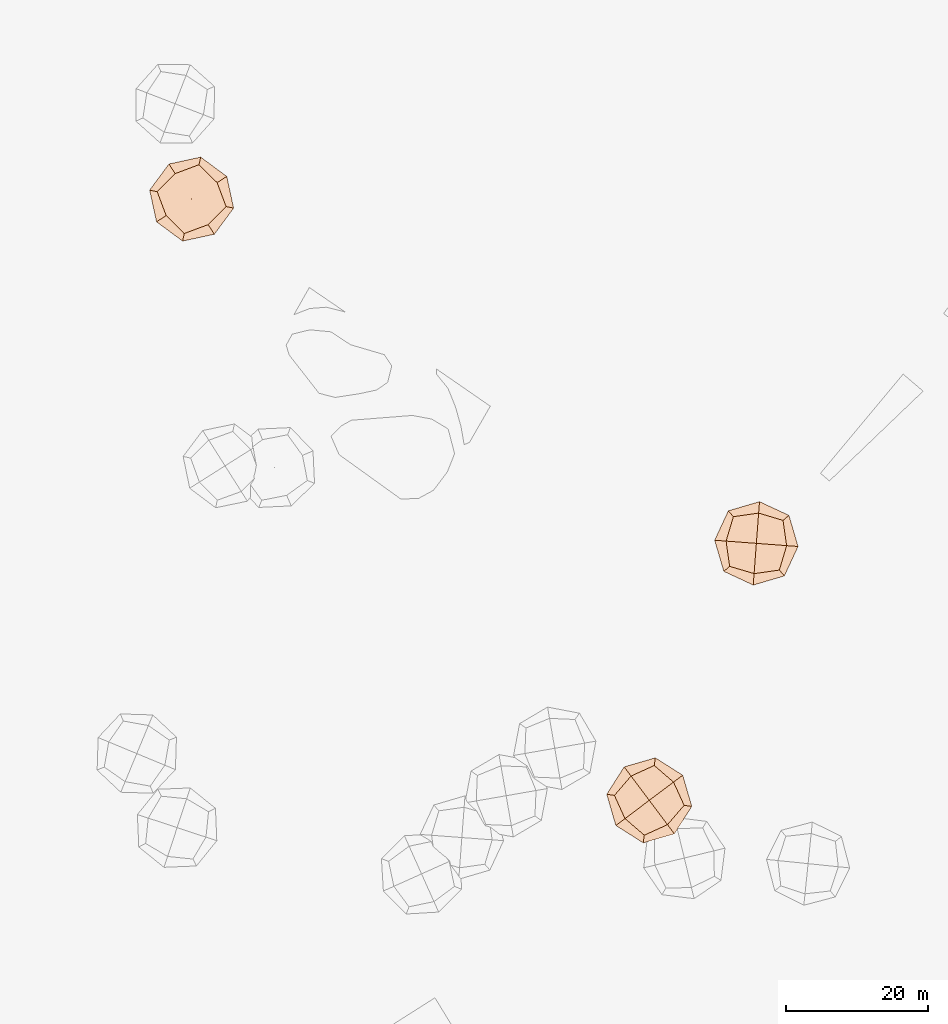
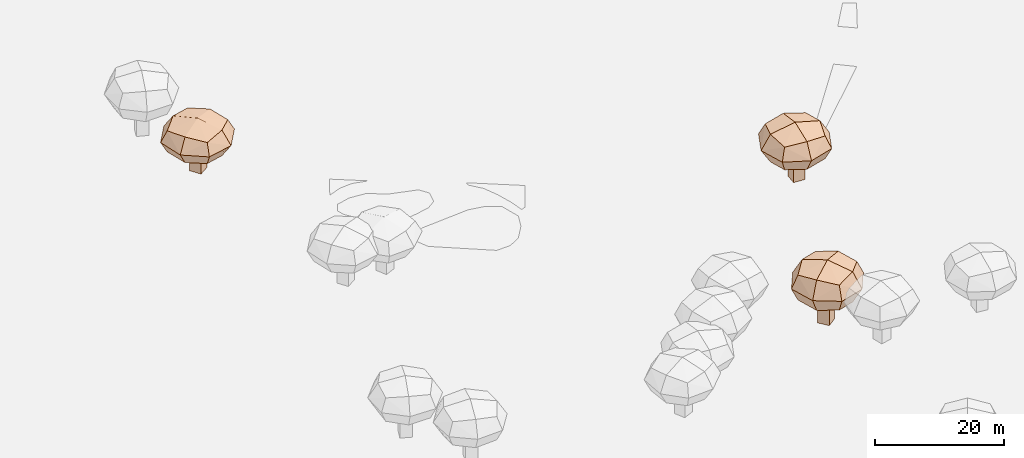
# Not in any storey, part 13 of 92: 3 geographic elements.
"""IFC4 model written with IfcOpenShell, lengths in metres."""

from ifc_helpers import new_model, si_unit, origin_with_axes, place, context, subcontext, project, spatial, triangles, material, element, save


model = new_model("IFC4")

# Units and contexts
model_context = context("Model", 3, precision=1e-05, world=origin_with_axes())
body_context = subcontext(model_context, "Body", "Model", "MODEL_VIEW")
ifc_project = project(units=[si_unit("VOLUMEUNIT", "CUBIC_METRE"), si_unit("LENGTHUNIT", "METRE"), si_unit("AREAUNIT", "SQUARE_METRE")], contexts=[model_context])

# Site
site_placement = place(None, origin_with_axes())
site = spatial("IfcSite", under=ifc_project, at=site_placement)

# Geographic elements
ifc_material = material(Name="tree")
geographic_element_1_placement = place(site_placement, origin_with_axes())
element("IfcGeographicElement", 1, at=geographic_element_1_placement, inside=site, material=ifc_material, Name="cw_instances_tree_165", context=body_context, shape_type="Tessellation", body=[
    triangles([(401.34333958082, -677.0755719799109, 5.6950024270316195), (401.34333958082, -677.0755719799109, 5.6950024270316195), (401.34333958082, -677.0755719799109, 5.6950024270316195), (401.34333958082, -677.0755719799109, 0.0), (401.34333958082, -677.0755719799109, 0.0), (401.34333958082, -677.0755719799109, 0.0), (402.4290647832255, -678.7552150327235, 5.6950024270316195), (402.4290647832255, -678.7552150327235, 5.6950024270316195), (402.4290647832255, -678.7552150327235, 5.6950024270316195), (402.4290647832255, -678.7552150327235, 0.0), (402.4290647832255, -678.7552150327235, 0.0), (402.4290647832255, -678.7552150327235, 0.0), (399.6636965280074, -678.1612971823165, 5.6950024270316195), (399.6636965280074, -678.1612971823165, 5.6950024270316195), (399.6636965280074, -678.1612971823165, 5.6950024270316195), (399.6636965280074, -678.1612971823165, 0.0), (399.6636965280074, -678.1612971823165, 0.0), (399.6636965280074, -678.1612971823165, 0.0), (400.7494217304129, -679.8409402351291, 5.6950024270316195), (400.7494217304129, -679.8409402351291, 5.6950024270316195), (400.7494217304129, -679.8409402351291, 5.6950024270316195), (400.7494217304129, -679.8409402351291, 0.0), (400.7494217304129, -679.8409402351291, 0.0), (400.7494217304129, -679.8409402351291, 0.0), (401.876833048676, -673.7538978813412, 8.483077568031336), (401.876833048676, -673.7538978813412, 8.483077568031336), (401.876833048676, -673.7538978813412, 8.483077568031336), (401.876833048676, -673.7538978813412, 8.483077568031336), (401.876833048676, -673.7538978813412, 8.483077568031336), (401.876833048676, -673.7538978813412, 8.483077568031336), (401.87683298965914, -673.75389734794, 4.49657602856928), (401.87683298965914, -673.75389734794, 4.49657602856928), (401.87683298965914, -673.75389734794, 4.49657602856928), (401.87683298965914, -673.75389734794, 4.49657602856928), (401.87683298965914, -673.75389734794, 4.49657602856928), (401.87683298965914, -673.75389734794, 4.49657602856928), (405.67687055207193, -679.6326470333963, 8.483077568031336), (405.67687055207193, -679.6326470333963, 8.483077568031336), (405.67687055207193, -679.6326470333963, 8.483077568031336), (405.67687055207193, -679.6326470333963, 8.483077568031336), (405.67687055207193, -679.6326470333963, 8.483077568031336), (405.67687055207193, -679.6326470333963, 8.483077568031336), (405.67687055207193, -679.6326470333963, 4.49657602856928), (405.67687055207193, -679.6326470333963, 4.49657602856928), (405.67687055207193, -679.6326470333963, 4.49657602856928), (405.67687055207193, -679.6326470333963, 4.49657602856928), (405.67687055207193, -679.6326470333963, 4.49657602856928), (405.67687055207193, -679.6326470333963, 4.49657602856928), (395.99808269953127, -677.5539353012138, 8.483077568031336), (395.99808269953127, -677.5539353012138, 8.483077568031336), (395.99808269953127, -677.5539353012138, 8.483077568031336), (395.99808269953127, -677.5539353012138, 8.483077568031336), (395.99808269953127, -677.5539353012138, 8.483077568031336), (395.99808269953127, -677.5539353012138, 8.483077568031336), (395.99808310264564, -677.5539350406398, 4.49657602856928), (395.99808310264564, -677.5539350406398, 4.49657602856928), (395.99808310264564, -677.5539350406398, 4.49657602856928), (395.99808310264564, -677.5539350406398, 4.49657602856928), (395.99808310264564, -677.5539350406398, 4.49657602856928), (395.99808310264564, -677.5539350406398, 4.49657602856928), (399.7981203922311, -683.4326851882273, 8.483077568031336), (399.7981203922311, -683.4326851882273, 8.483077568031336), (399.7981203922311, -683.4326851882273, 8.483077568031336), (399.7981203922311, -683.4326851882273, 8.483077568031336), (399.7981203922311, -683.4326851882273, 8.483077568031336), (399.7981203922311, -683.4326851882273, 8.483077568031336), (399.79812026194406, -683.4326849866701, 4.49657602856928), (399.79812026194406, -683.4326849866701, 4.49657602856928), (399.79812026194406, -683.4326849866701, 4.49657602856928), (399.79812026194406, -683.4326849866701, 4.49657602856928), (399.79812026194406, -683.4326849866701, 4.49657602856928), (399.79812026194406, -683.4326849866701, 4.49657602856928), (397.2539795059944, -680.9096722574463, 4.059784066264723), (397.2539795059944, -680.9096722574463, 4.059784066264723), (397.2539795059944, -680.9096722574463, 4.059784066264723), (397.2539795059944, -680.9096722574463, 4.059784066264723), (398.5210959987189, -675.0097944507058, 4.059784066264723), (398.5210959987189, -675.0097944507058, 4.059784066264723), (398.5210959987189, -675.0097944507058, 4.059784066264723), (398.5210959987189, -675.0097944507058, 4.059784066264723), (402.1045927677027, -672.6934137480861, 6.489827140000474), (402.1045927677027, -672.6934137480861, 6.489827140000474), (402.1045927677027, -672.6934137480861, 6.489827140000474), (402.1045927677027, -672.6934137480861, 6.489827140000474), (399.5703602194714, -684.4931690432265, 6.489827140000474), (399.5703602194714, -684.4931690432265, 6.489827140000474), (399.5703602194714, -684.4931690432265, 6.489827140000474), (399.5703602194714, -684.4931690432265, 6.489827140000474), (406.7373548608042, -679.8604074844119, 6.489827140000474), (406.7373548608042, -679.8604074844119, 6.489827140000474), (406.7373548608042, -679.8604074844119, 6.489827140000474), (406.7373548608042, -679.8604074844119, 6.489827140000474), (394.9375991793458, -677.3261751858975, 6.489827140000474), (394.9375991793458, -677.3261751858975, 6.489827140000474), (394.9375991793458, -677.3261751858975, 6.489827140000474), (394.9375991793458, -677.3261751858975, 6.489827140000474), (403.1538576971043, -682.1767884421771, 8.919869188635726), (403.1538576971043, -682.1767884421771, 8.919869188635726), (403.1538576971043, -682.1767884421771, 8.919869188635726), (403.1538576971043, -682.1767884421771, 8.919869188635726), (404.4209738378955, -676.2769102199334, 8.919870526961377), (404.4209738378955, -676.2769102199334, 8.919870526961377), (404.4209738378955, -676.2769102199334, 8.919870526961377), (404.4209738378955, -676.2769102199334, 8.919870526961377), (403.15385739996776, -682.1767880746041, 4.059784066264723), (403.15385739996776, -682.1767880746041, 4.059784066264723), (403.15385739996776, -682.1767880746041, 4.059784066264723), (403.15385739996776, -682.1767880746041, 4.059784066264723), (397.2539794842799, -680.9096722238535, 8.919869188635726), (397.2539794842799, -680.9096722238535, 8.919869188635726), (397.2539794842799, -680.9096722238535, 8.919869188635726), (397.2539794842799, -680.9096722238535, 8.919869188635726), (398.5210960239135, -675.00979443442, 8.919870526961377), (398.5210960239135, -675.00979443442, 8.919870526961377), (398.5210960239135, -675.00979443442, 8.919870526961377), (398.5210960239135, -675.00979443442, 8.919870526961377), (404.4209734757511, -676.2769105254681, 4.059784066264723), (404.4209734757511, -676.2769105254681, 4.059784066264723), (404.4209734757511, -676.2769105254681, 4.059784066264723), (404.4209734757511, -676.2769105254681, 4.059784066264723), (400.8374765690094, -678.59329116234, 9.836520290307751), (400.8374765690094, -678.59329116234, 9.836520290307751), (400.8374765690094, -678.59329116234, 9.836520290307751), (400.8374765690094, -678.59329116234, 9.836520290307751), (400.8374765690094, -678.59329116234, 9.836520290307751), (400.8374765690094, -678.59329116234, 9.836520290307751), (400.8374765690094, -678.59329116234, 9.836520290307751), (400.8374765690094, -678.59329116234, 9.836520290307751), (404.02763177296646, -683.5285379944561, 6.489827140000474), (404.02763177296646, -683.5285379944561, 6.489827140000474), (404.02763177296646, -683.5285379944561, 6.489827140000474), (404.02763177296646, -683.5285379944561, 6.489827140000474), (404.02763177296646, -683.5285379944561, 6.489827140000474), (404.02763177296646, -683.5285379944561, 6.489827140000474), (404.02763177296646, -683.5285379944561, 6.489827140000474), (404.02763177296646, -683.5285379944561, 6.489827140000474), (395.9022299374295, -681.7834463081139, 6.489827140000474), (395.9022299374295, -681.7834463081139, 6.489827140000474), (395.9022299374295, -681.7834463081139, 6.489827140000474), (395.9022299374295, -681.7834463081139, 6.489827140000474), (395.9022299374295, -681.7834463081139, 6.489827140000474), (395.9022299374295, -681.7834463081139, 6.489827140000474), (395.9022299374295, -681.7834463081139, 6.489827140000474), (395.9022299374295, -681.7834463081139, 6.489827140000474), (400.83747668658447, -678.5932910863394, 3.1431346446185144), (400.83747668658447, -678.5932910863394, 3.1431346446185144), (400.83747668658447, -678.5932910863394, 3.1431346446185144), (400.83747668658447, -678.5932910863394, 3.1431346446185144), (400.83747668658447, -678.5932910863394, 3.1431346446185144), (400.83747668658447, -678.5932910863394, 3.1431346446185144), (400.83747668658447, -678.5932910863394, 3.1431346446185144), (400.83747668658447, -678.5932910863394, 3.1431346446185144), (405.7727229574579, -675.4031363404291, 6.489827140000474), (405.7727229574579, -675.4031363404291, 6.489827140000474), (405.7727229574579, -675.4031363404291, 6.489827140000474), (405.7727229574579, -675.4031363404291, 6.489827140000474), (405.7727229574579, -675.4031363404291, 6.489827140000474), (405.7727229574579, -675.4031363404291, 6.489827140000474), (405.7727229574579, -675.4031363404291, 6.489827140000474), (405.7727229574579, -675.4031363404291, 6.489827140000474), (397.64732162029156, -673.6580445224557, 6.489827140000474), (397.64732162029156, -673.6580445224557, 6.489827140000474), (397.64732162029156, -673.6580445224557, 6.489827140000474), (397.64732162029156, -673.6580445224557, 6.489827140000474), (397.64732162029156, -673.6580445224557, 6.489827140000474), (397.64732162029156, -673.6580445224557, 6.489827140000474), (397.64732162029156, -673.6580445224557, 6.489827140000474), (397.64732162029156, -673.6580445224557, 6.489827140000474)], [[15, 8, 2], [7, 24, 11], [19, 16, 22], [4, 23, 17], [3, 12, 6], [14, 5, 18], [26, 127, 101], [54, 123, 114], [124, 66, 98], [128, 38, 102], [45, 133, 108], [40, 135, 89], [130, 63, 88], [131, 70, 105], [68, 141, 73], [61, 140, 86], [137, 49, 93], [142, 56, 74], [59, 145, 75], [31, 149, 79], [150, 43, 107], [146, 71, 76], [35, 154, 120], [30, 157, 83], [158, 42, 91], [153, 47, 119], [58, 164, 77], [51, 162, 96], [167, 28, 81], [165, 33, 80], [15, 21, 8], [7, 20, 24], [19, 13, 16], [4, 10, 23], [3, 9, 12], [14, 1, 5], [25, 115, 126], [53, 111, 121], [122, 112, 65], [125, 99, 37], [46, 90, 136], [39, 100, 134], [132, 97, 64], [129, 87, 69], [67, 85, 138], [62, 110, 144], [143, 109, 50], [139, 94, 55], [60, 78, 147], [32, 117, 151], [152, 118, 44], [148, 106, 72], [36, 84, 160], [29, 104, 156], [155, 103, 41], [159, 92, 48], [57, 95, 161], [52, 113, 163], [166, 116, 27], [168, 82, 34]], closed=True),
])
geographic_element_2_placement = place(site_placement, origin_with_axes())
element("IfcGeographicElement", 2, at=geographic_element_2_placement, inside=site, material=ifc_material, Name="cw_instances_tree_195", context=body_context, shape_type="Tessellation", body=[
    triangles([(463.6097291003333, -762.7031589546891, 6.750914616974639), (463.6097291003333, -762.7031589546891, 6.750914616974639), (463.6097291003333, -762.7031589546891, 6.750914616974639), (463.6097291003333, -762.7031589546891, 0.0), (463.6097291003333, -762.7031589546891, 0.0), (463.6097291003333, -762.7031589546891, 0.0), (465.2090115389696, -761.5022028016721, 6.750914616974639), (465.2090115389696, -761.5022028016721, 6.750914616974639), (465.2090115389696, -761.5022028016721, 6.750914616974639), (465.2090115389696, -761.5022028016721, 0.0), (465.2090115389696, -761.5022028016721, 0.0), (465.2090115389696, -761.5022028016721, 0.0), (464.8106852533504, -764.3024413933255, 6.750914616974639), (464.8106852533504, -764.3024413933255, 6.750914616974639), (464.8106852533504, -764.3024413933255, 6.750914616974639), (464.8106852533504, -764.3024413933255, 0.0), (464.8106852533504, -764.3024413933255, 0.0), (464.8106852533504, -764.3024413933255, 0.0), (466.4099676919867, -763.1014852403083, 6.750914616974639), (466.4099676919867, -763.1014852403083, 6.750914616974639), (466.4099676919867, -763.1014852403083, 6.750914616974639), (466.4099676919867, -763.1014852403083, 0.0), (466.4099676919867, -763.1014852403083, 0.0), (466.4099676919867, -763.1014852403083, 0.0), (460.25879880928454, -762.4041601555518, 10.05592764616296), (460.25879880928454, -762.4041601555518, 10.05592764616296), (460.25879880928454, -762.4041601555518, 10.05592764616296), (460.25879880928454, -762.4041601555518, 10.05592764616296), (460.25879880928454, -762.4041601555518, 10.05592764616296), (460.25879880928454, -762.4041601555518, 10.05592764616296), (460.258798281342, -762.4041602518674, 5.330287603306334), (460.258798281342, -762.4041602518674, 5.330287603306334), (460.258798281342, -762.4041602518674, 5.330287603306334), (460.258798281342, -762.4041602518674, 5.330287603306334), (460.258798281342, -762.4041602518674, 5.330287603306334), (460.258798281342, -762.4041602518674, 5.330287603306334), (465.8562858649959, -758.2008144308766, 10.05592764616296), (465.8562858649959, -758.2008144308766, 10.05592764616296), (465.8562858649959, -758.2008144308766, 10.05592764616296), (465.8562858649959, -758.2008144308766, 10.05592764616296), (465.8562858649959, -758.2008144308766, 10.05592764616296), (465.8562858649959, -758.2008144308766, 10.05592764616296), (465.8562858649959, -758.2008144308766, 5.330287603306334), (465.8562858649959, -758.2008144308766, 5.330287603306334), (465.8562858649959, -758.2008144308766, 5.330287603306334), (465.8562858649959, -758.2008144308766, 5.330287603306334), (465.8562858649959, -758.2008144308766, 5.330287603306334), (465.8562858649959, -758.2008144308766, 5.330287603306334), (464.4621445346771, -768.0016484112631, 10.05592764616296), (464.4621445346771, -768.0016484112631, 10.05592764616296), (464.4621445346771, -768.0016484112631, 10.05592764616296), (464.4621445346771, -768.0016484112631, 10.05592764616296), (464.4621445346771, -768.0016484112631, 10.05592764616296), (464.4621445346771, -768.0016484112631, 10.05592764616296), (464.4621442464477, -768.0016480274353, 5.330287603306334), (464.4621442464477, -768.0016480274353, 5.330287603306334), (464.4621442464477, -768.0016480274353, 5.330287603306334), (464.4621442464477, -768.0016480274353, 5.330287603306334), (464.4621442464477, -768.0016480274353, 5.330287603306334), (464.4621442464477, -768.0016480274353, 5.330287603306334), (470.0596323102449, -763.7983024461574, 10.05592764616296), (470.0596323102449, -763.7983024461574, 10.05592764616296), (470.0596323102449, -763.7983024461574, 10.05592764616296), (470.0596323102449, -763.7983024461574, 10.05592764616296), (470.0596323102449, -763.7983024461574, 10.05592764616296), (470.0596323102449, -763.7983024461574, 10.05592764616296), (470.059632118331, -763.7983025902721, 5.330287603306334), (470.059632118331, -763.7983025902721, 5.330287603306334), (470.059632118331, -763.7983025902721, 5.330287603306334), (470.059632118331, -763.7983025902721, 5.330287603306334), (470.059632118331, -763.7983025902721, 5.330287603306334), (470.059632118331, -763.7983025902721, 5.330287603306334), (467.72144005914754, -766.5132801799183, 4.812509905986574), (467.72144005914754, -766.5132801799183, 4.812509905986574), (467.72144005914754, -766.5132801799183, 4.812509905986574), (467.72144005914754, -766.5132801799183, 4.812509905986574), (461.7471668106951, -765.6634557901598, 4.812509905986574), (461.7471668106951, -765.6634557901598, 4.812509905986574), (461.7471668106951, -765.6634557901598, 4.812509905986574), (461.7471668106951, -765.6634557901598, 4.812509905986574), (459.1849423625771, -762.2514073540656, 7.693108029789548), (459.1849423625771, -762.2514073540656, 7.693108029789548), (459.1849423625771, -762.2514073540656, 7.693108029789548), (459.1849423625771, -762.2514073540656, 7.693108029789548), (471.1334885112346, -763.9510557197907, 7.693108029789548), (471.1334885112346, -763.9510557197907, 7.693108029789548), (471.1334885112346, -763.9510557197907, 7.693108029789548), (471.1334885112346, -763.9510557197907, 7.693108029789548), (466.00903938434703, -757.1269577577399, 7.693108029789548), (466.00903938434703, -757.1269577577399, 7.693108029789548), (466.00903938434703, -757.1269577577399, 7.693108029789548), (466.00903938434703, -757.1269577577399, 7.693108029789548), (464.3093912948418, -769.0755042742325, 7.693108029789548), (464.3093912948418, -769.0755042742325, 7.693108029789548), (464.3093912948418, -769.0755042742325, 7.693108029789548), (464.3093912948418, -769.0755042742325, 7.693108029789548), (468.57126411468977, -760.5390065696655, 10.573704938427817), (468.57126411468977, -760.5390065696655, 10.573704938427817), (468.57126411468977, -760.5390065696655, 10.573704938427817), (468.57126411468977, -760.5390065696655, 10.573704938427817), (462.5969904764645, -759.68918256014, 10.573706524892849), (462.5969904764645, -759.68918256014, 10.573706524892849), (462.5969904764645, -759.68918256014, 10.573706524892849), (462.5969904764645, -759.68918256014, 10.573706524892849), (468.5712637688823, -760.5390068918723, 4.812509905986574), (468.5712637688823, -760.5390068918723, 4.812509905986574), (468.5712637688823, -760.5390068918723, 4.812509905986574), (468.5712637688823, -760.5390068918723, 4.812509905986574), (467.7214400271619, -766.5132802039374, 10.573704938427817), (467.7214400271619, -766.5132802039374, 10.573704938427817), (467.7214400271619, -766.5132802039374, 10.573704938427817), (467.7214400271619, -766.5132802039374, 10.573704938427817), (461.74716679268073, -765.6634557661705, 10.573706524892849), (461.74716679268073, -765.6634557661705, 10.573706524892849), (461.74716679268073, -765.6634557661705, 10.573706524892849), (461.74716679268073, -765.6634557661705, 10.573706524892849), (462.5969908066677, -759.6891828999427, 4.812509905986574), (462.5969908066677, -759.6891828999427, 4.812509905986574), (462.5969908066677, -759.6891828999427, 4.812509905986574), (462.5969908066677, -759.6891828999427, 4.812509905986574), (465.1592151988706, -763.1012314780704, 11.660312608965553), (465.1592151988706, -763.1012314780704, 11.660312608965553), (465.1592151988706, -763.1012314780704, 11.660312608965553), (465.1592151988706, -763.1012314780704, 11.660312608965553), (465.1592151988706, -763.1012314780704, 11.660312608965553), (465.1592151988706, -763.1012314780704, 11.660312608965553), (465.1592151988706, -763.1012314780704, 11.660312608965553), (465.1592151988706, -763.1012314780704, 11.660312608965553), (469.85834074491436, -759.5724964891879, 7.693108029789548), (469.85834074491436, -759.5724964891879, 7.693108029789548), (469.85834074491436, -759.5724964891879, 7.693108029789548), (469.85834074491436, -759.5724964891879, 7.693108029789548), (469.85834074491436, -759.5724964891879, 7.693108029789548), (469.85834074491436, -759.5724964891879, 7.693108029789548), (469.85834074491436, -759.5724964891879, 7.693108029789548), (469.85834074491436, -759.5724964891879, 7.693108029789548), (468.6879501156359, -767.8003568281572, 7.693108029789548), (468.6879501156359, -767.8003568281572, 7.693108029789548), (468.6879501156359, -767.8003568281572, 7.693108029789548), (468.6879501156359, -767.8003568281572, 7.693108029789548), (468.6879501156359, -767.8003568281572, 7.693108029789548), (468.6879501156359, -767.8003568281572, 7.693108029789548), (468.6879501156359, -767.8003568281572, 7.693108029789548), (468.6879501156359, -767.8003568281572, 7.693108029789548), (465.15921511480366, -763.1012313661206, 3.72590422696877), (465.15921511480366, -763.1012313661206, 3.72590422696877), (465.15921511480366, -763.1012313661206, 3.72590422696877), (465.15921511480366, -763.1012313661206, 3.72590422696877), (465.15921511480366, -763.1012313661206, 3.72590422696877), (465.15921511480366, -763.1012313661206, 3.72590422696877), (465.15921511480366, -763.1012313661206, 3.72590422696877), (465.15921511480366, -763.1012313661206, 3.72590422696877), (461.63048062223675, -758.4021063477802, 7.693108029789548), (461.63048062223675, -758.4021063477802, 7.693108029789548), (461.63048062223675, -758.4021063477802, 7.693108029789548), (461.63048062223675, -758.4021063477802, 7.693108029789548), (461.63048062223675, -758.4021063477802, 7.693108029789548), (461.63048062223675, -758.4021063477802, 7.693108029789548), (461.63048062223675, -758.4021063477802, 7.693108029789548), (461.63048062223675, -758.4021063477802, 7.693108029789548), (460.4600898266666, -766.6299661988488, 7.693108029789548), (460.4600898266666, -766.6299661988488, 7.693108029789548), (460.4600898266666, -766.6299661988488, 7.693108029789548), (460.4600898266666, -766.6299661988488, 7.693108029789548), (460.4600898266666, -766.6299661988488, 7.693108029789548), (460.4600898266666, -766.6299661988488, 7.693108029789548), (460.4600898266666, -766.6299661988488, 7.693108029789548), (460.4600898266666, -766.6299661988488, 7.693108029789548)], [[15, 8, 2], [7, 24, 11], [19, 16, 22], [4, 23, 17], [3, 12, 6], [14, 5, 18], [26, 127, 101], [54, 123, 114], [124, 66, 98], [128, 38, 102], [45, 133, 108], [40, 135, 89], [130, 63, 88], [131, 70, 105], [68, 141, 73], [61, 140, 86], [137, 49, 93], [142, 56, 74], [59, 145, 75], [31, 149, 79], [150, 43, 107], [146, 71, 76], [35, 154, 120], [30, 157, 83], [158, 42, 91], [153, 47, 119], [58, 164, 77], [51, 162, 96], [167, 28, 81], [165, 33, 80], [15, 21, 8], [7, 20, 24], [19, 13, 16], [4, 10, 23], [3, 9, 12], [14, 1, 5], [25, 115, 126], [53, 111, 121], [122, 112, 65], [125, 99, 37], [46, 90, 136], [39, 100, 134], [132, 97, 64], [129, 87, 69], [67, 85, 138], [62, 110, 144], [143, 109, 50], [139, 94, 55], [60, 78, 147], [32, 117, 151], [152, 118, 44], [148, 106, 72], [36, 84, 160], [29, 104, 156], [155, 103, 41], [159, 92, 48], [57, 95, 161], [52, 113, 163], [166, 116, 27], [168, 82, 34]], closed=True),
])
geographic_element_3_placement = place(site_placement, origin_with_axes())
element("IfcGeographicElement", 3, at=geographic_element_3_placement, inside=site, material=ifc_material, Name="cw_instances_tree_198", context=body_context, shape_type="Tessellation", body=[
    triangles([(481.5316997715054, -726.0758313709166, 6.140043077276193), (481.5316997715054, -726.0758313709166, 6.140043077276193), (481.5316997715054, -726.0758313709166, 6.140043077276193), (481.5316997715054, -726.0758313709166, 0.0), (481.5316997715054, -726.0758313709166, 0.0), (481.5316997715054, -726.0758313709166, 0.0), (481.3823345922384, -728.0702460828616, 6.140043077276193), (481.3823345922384, -728.0702460828616, 6.140043077276193), (481.3823345922384, -728.0702460828616, 6.140043077276193), (481.3823345922384, -728.0702460828616, 0.0), (481.3823345922384, -728.0702460828616, 0.0), (481.3823345922384, -728.0702460828616, 0.0), (479.53728505956036, -725.9264661916496, 6.140043077276193), (479.53728505956036, -725.9264661916496, 6.140043077276193), (479.53728505956036, -725.9264661916496, 6.140043077276193), (479.53728505956036, -725.9264661916496, 0.0), (479.53728505956036, -725.9264661916496, 0.0), (479.53728505956036, -725.9264661916496, 0.0), (479.3879198802934, -727.9208809035946, 6.140043077276193), (479.3879198802934, -727.9208809035946, 6.140043077276193), (479.3879198802934, -727.9208809035946, 6.140043077276193), (479.3879198802934, -727.9208809035946, 0.0), (479.3879198802934, -727.9208809035946, 0.0), (479.3879198802934, -727.9208809035946, 0.0), (483.9633712223806, -723.7509425451118, 9.145994644068406), (483.9633712223806, -723.7509425451118, 9.145994644068406), (483.9633712223806, -723.7509425451118, 9.145994644068406), (483.9633712223806, -723.7509425451118, 9.145994644068406), (483.9633712223806, -723.7509425451118, 9.145994644068406), (483.9633712223806, -723.7509425451118, 9.145994644068406), (483.963371497558, -723.7509420843761, 4.847964661896287), (483.963371497558, -723.7509420843761, 4.847964661896287), (483.963371497558, -723.7509420843761, 4.847964661896287), (483.963371497558, -723.7509420843761, 4.847964661896287), (483.963371497558, -723.7509420843761, 4.847964661896287), (483.963371497558, -723.7509420843761, 4.847964661896287), (483.44059345899586, -730.7313923895067, 9.145994644068406), (483.44059345899586, -730.7313923895067, 9.145994644068406), (483.44059345899586, -730.7313923895067, 9.145994644068406), (483.44059345899586, -730.7313923895067, 9.145994644068406), (483.44059345899586, -730.7313923895067, 9.145994644068406), (483.44059345899586, -730.7313923895067, 9.145994644068406), (483.44059345899586, -730.7313923895067, 4.847964661896287), (483.44059345899586, -730.7313923895067, 4.847964661896287), (483.44059345899586, -730.7313923895067, 4.847964661896287), (483.44059345899586, -730.7313923895067, 4.847964661896287), (483.44059345899586, -730.7313923895067, 4.847964661896287), (483.44059345899586, -730.7313923895067, 4.847964661896287), (476.98292047443806, -723.2281639920425, 9.145994644068406), (476.98292047443806, -723.2281639920425, 9.145994644068406), (476.98292047443806, -723.2281639920425, 9.145994644068406), (476.98292047443806, -723.2281639920425, 9.145994644068406), (476.98292047443806, -723.2281639920425, 9.145994644068406), (476.98292047443806, -723.2281639920425, 9.145994644068406), (476.98292095309756, -723.2281640278901, 4.847964661896287), (476.98292095309756, -723.2281640278901, 4.847964661896287), (476.98292095309756, -723.2281640278901, 4.847964661896287), (476.98292095309756, -723.2281640278901, 4.847964661896287), (476.98292095309756, -723.2281640278901, 4.847964661896287), (476.98292095309756, -723.2281640278901, 4.847964661896287), (476.4601424179521, -730.208614536503, 9.145994644068406), (476.4601424179521, -730.208614536503, 9.145994644068406), (476.4601424179521, -730.208614536503, 9.145994644068406), (476.4601424179521, -730.208614536503, 9.145994644068406), (476.4601424179521, -730.208614536503, 9.145994644068406), (476.4601424179521, -730.208614536503, 9.145994644068406), (476.4601424358759, -730.2086142971732, 4.847964661896287), (476.4601424358759, -730.2086142971732, 4.847964661896287), (476.4601424358759, -730.2086142971732, 4.847964661896287), (476.4601424358759, -730.2086142971732, 4.847964661896287), (476.4601424358759, -730.2086142971732, 4.847964661896287), (476.4601424358759, -730.2086142971732, 4.847964661896287), (475.9566984130044, -726.6611096060213, 4.377039232325248), (475.9566984130044, -726.6611096060213, 4.377039232325248), (475.9566984130044, -726.6611096060213, 4.377039232325248), (475.9566984130044, -726.6611096060213, 4.377039232325248), (480.5304256769328, -722.7247202381104, 4.377039232325248), (480.5304256769328, -722.7247202381104, 4.377039232325248), (480.5304256769328, -722.7247202381104, 4.377039232325248), (480.5304256769328, -722.7247202381104, 4.377039232325248), (484.7854837169735, -723.043388919772, 6.996980021384954), (484.7854837169735, -723.043388919772, 6.996980021384954), (484.7854837169735, -723.043388919772, 6.996980021384954), (484.7854837169735, -723.043388919772, 6.996980021384954), (475.63802972984917, -730.9161676660061, 6.996980021384954), (475.63802972984917, -730.9161676660061, 6.996980021384954), (475.63802972984917, -730.9161676660061, 6.996980021384954), (475.63802972984917, -730.9161676660061, 6.996980021384954), (484.1481467820091, -731.5535055734462, 6.996980021384954), (484.1481467820091, -731.5535055734462, 6.996980021384954), (484.1481467820091, -731.5535055734462, 6.996980021384954), (484.1481467820091, -731.5535055734462, 6.996980021384954), (476.2753675770597, -722.406051551968, 6.996980021384954), (476.2753675770597, -722.406051551968, 6.996980021384954), (476.2753675770597, -722.406051551968, 6.996980021384954), (476.2753675770597, -722.406051551968, 6.996980021384954), (479.89308827328097, -731.2348368566837, 9.616919705236839), (479.89308827328097, -731.2348368566837, 9.616919705236839), (479.89308827328097, -731.2348368566837, 9.616919705236839), (479.89308827328097, -731.2348368566837, 9.616919705236839), (484.46681550773343, -727.2984469450532, 9.616921148147048), (484.46681550773343, -727.2984469450532, 9.616921148147048), (484.46681550773343, -727.2984469450532, 9.616921148147048), (484.46681550773343, -727.2984469450532, 9.616921148147048), (479.8930882585214, -731.2348363842622, 4.377039232325248), (479.8930882585214, -731.2348363842622, 4.377039232325248), (479.8930882585214, -731.2348363842622, 4.377039232325248), (479.8930882585214, -731.2348363842622, 4.377039232325248), (475.95669841599175, -726.661109566133, 9.616919705236839), (475.95669841599175, -726.661109566133, 9.616919705236839), (475.95669841599175, -726.661109566133, 9.616919705236839), (475.95669841599175, -726.661109566133, 9.616919705236839), (480.53042570684903, -722.724720240351, 9.616921148147048), (480.53042570684903, -722.724720240351, 9.616921148147048), (480.53042570684903, -722.724720240351, 9.616921148147048), (480.53042570684903, -722.724720240351, 9.616921148147048), (484.46681503456506, -727.2984469697848, 4.377039232325248), (484.46681503456506, -727.2984469697848, 4.377039232325248), (484.46681503456506, -727.2984469697848, 4.377039232325248), (484.46681503456506, -727.2984469697848, 4.377039232325248), (480.2117569244565, -726.9797781525117, 10.60520326142709), (480.2117569244565, -726.9797781525117, 10.60520326142709), (480.2117569244565, -726.9797781525117, 10.60520326142709), (480.2117569244565, -726.9797781525117, 10.60520326142709), (480.2117569244565, -726.9797781525117, 10.60520326142709), (480.2117569244565, -726.9797781525117, 10.60520326142709), (480.2117569244565, -726.9797781525117, 10.60520326142709), (480.2117569244565, -726.9797781525117, 10.60520326142709), (479.7728815937355, -732.8399095472271, 6.996980021384954), (479.7728815937355, -732.8399095472271, 6.996980021384954), (479.7728815937355, -732.8399095472271, 6.996980021384954), (479.7728815937355, -732.8399095472271, 6.996980021384954), (479.7728815937355, -732.8399095472271, 6.996980021384954), (479.7728815937355, -732.8399095472271, 6.996980021384954), (479.7728815937355, -732.8399095472271, 6.996980021384954), (479.7728815937355, -732.8399095472271, 6.996980021384954), (474.35162572470165, -726.5409028965596, 6.996980021384954), (474.35162572470165, -726.5409028965596, 6.996980021384954), (474.35162572470165, -726.5409028965596, 6.996980021384954), (474.35162572470165, -726.5409028965596, 6.996980021384954), (474.35162572470165, -726.5409028965596, 6.996980021384954), (474.35162572470165, -726.5409028965596, 6.996980021384954), (474.35162572470165, -726.5409028965596, 6.996980021384954), (474.35162572470165, -726.5409028965596, 6.996980021384954), (480.2117570640655, -726.9797781629672, 3.388757487447814), (480.2117570640655, -726.9797781629672, 3.388757487447814), (480.2117570640655, -726.9797781629672, 3.388757487447814), (480.2117570640655, -726.9797781629672, 3.388757487447814), (480.2117570640655, -726.9797781629672, 3.388757487447814), (480.2117570640655, -726.9797781629672, 3.388757487447814), (480.2117570640655, -726.9797781629672, 3.388757487447814), (480.2117570640655, -726.9797781629672, 3.388757487447814), (486.07188773481704, -727.4186535196933, 6.996980021384954), (486.07188773481704, -727.4186535196933, 6.996980021384954), (486.07188773481704, -727.4186535196933, 6.996980021384954), (486.07188773481704, -727.4186535196933, 6.996980021384954), (486.07188773481704, -727.4186535196933, 6.996980021384954), (486.07188773481704, -727.4186535196933, 6.996980021384954), (486.07188773481704, -727.4186535196933, 6.996980021384954), (486.07188773481704, -727.4186535196933, 6.996980021384954), (480.65063234246554, -721.1196470651736, 6.996980021384954), (480.65063234246554, -721.1196470651736, 6.996980021384954), (480.65063234246554, -721.1196470651736, 6.996980021384954), (480.65063234246554, -721.1196470651736, 6.996980021384954), (480.65063234246554, -721.1196470651736, 6.996980021384954), (480.65063234246554, -721.1196470651736, 6.996980021384954), (480.65063234246554, -721.1196470651736, 6.996980021384954), (480.65063234246554, -721.1196470651736, 6.996980021384954)], [[15, 8, 2], [7, 24, 11], [19, 16, 22], [4, 23, 17], [3, 12, 6], [14, 5, 18], [26, 127, 101], [54, 123, 114], [124, 66, 98], [128, 38, 102], [45, 133, 108], [40, 135, 89], [130, 63, 88], [131, 70, 105], [68, 141, 73], [61, 140, 86], [137, 49, 93], [142, 56, 74], [59, 145, 75], [31, 149, 79], [150, 43, 107], [146, 71, 76], [35, 154, 120], [30, 157, 83], [158, 42, 91], [153, 47, 119], [58, 164, 77], [51, 162, 96], [167, 28, 81], [165, 33, 80], [15, 21, 8], [7, 20, 24], [19, 13, 16], [4, 10, 23], [3, 9, 12], [14, 1, 5], [25, 115, 126], [53, 111, 121], [122, 112, 65], [125, 99, 37], [46, 90, 136], [39, 100, 134], [132, 97, 64], [129, 87, 69], [67, 85, 138], [62, 110, 144], [143, 109, 50], [139, 94, 55], [60, 78, 147], [32, 117, 151], [152, 118, 44], [148, 106, 72], [36, 84, 160], [29, 104, 156], [155, 103, 41], [159, 92, 48], [57, 95, 161], [52, 113, 163], [166, 116, 27], [168, 82, 34]], closed=True),
])

save(model, "model.ifc")
